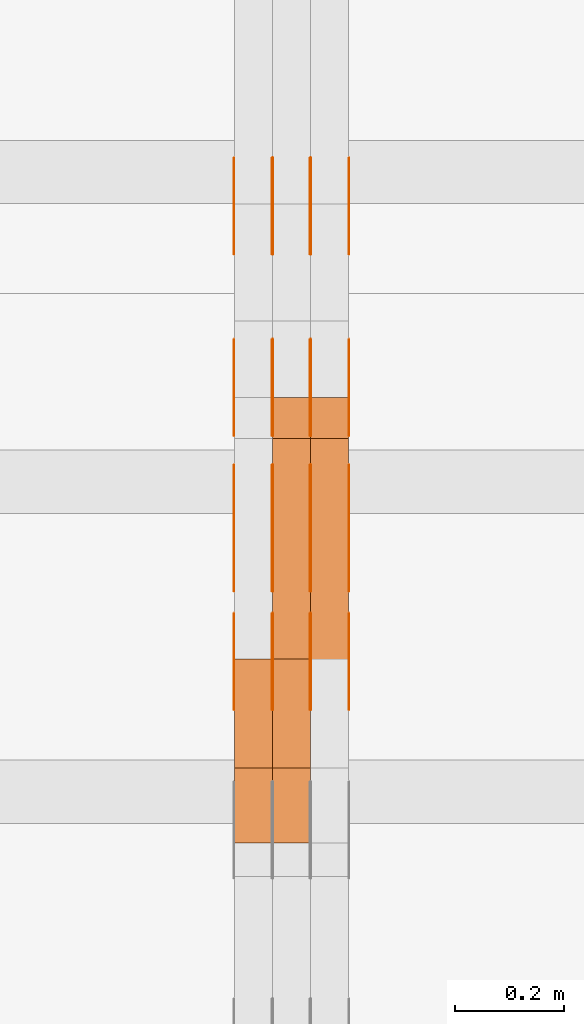
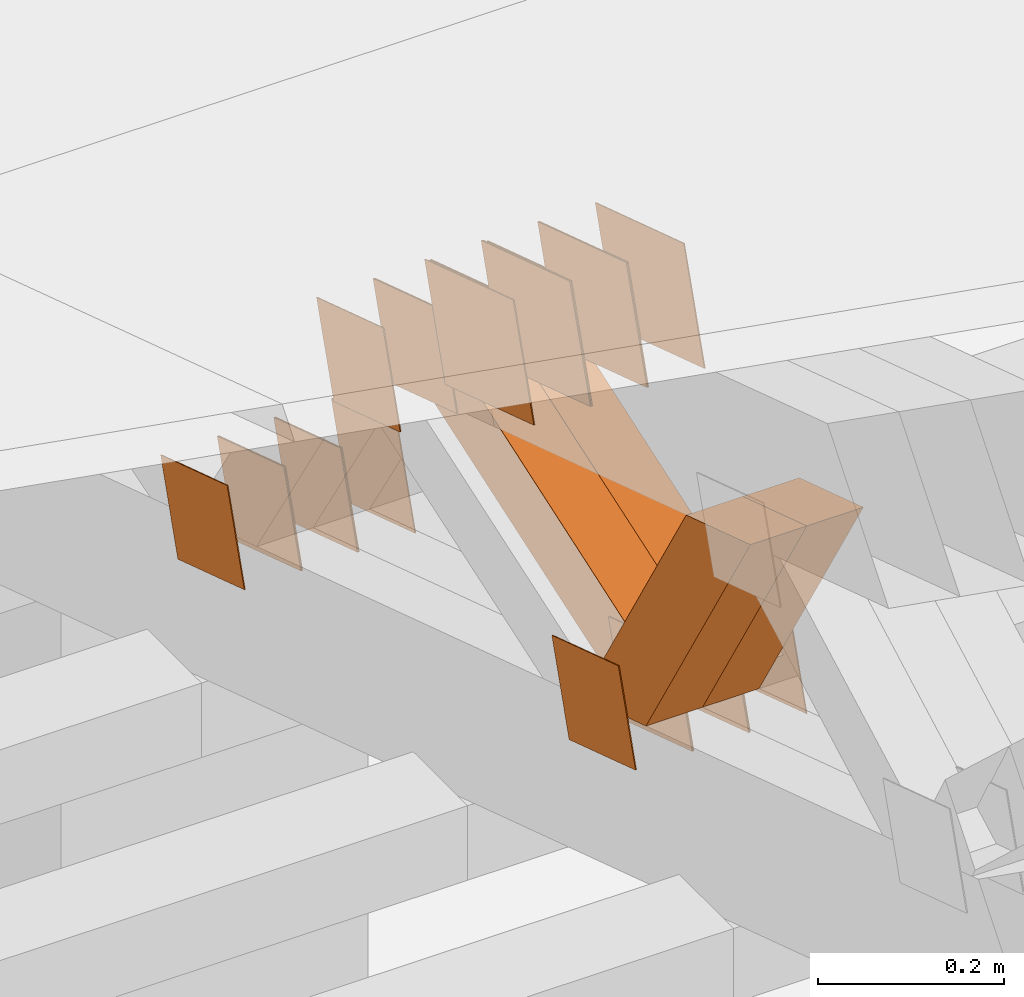
# One storey, part 226 of 385: 28 proxies.
"""IFC2X3 building model written with IfcOpenShell, lengths in millimetres."""

from ifc_helpers import new_model, entity, si_unit, converted_unit, derived_unit, direction, frame, origin, place, context, subcontext, project, spatial, polyline, outline, extrude, source, transform, mapped, material, type_object, type_shapes, element, save


model = new_model("IFC2X3")

# Units and contexts
model_context = context("Model", 3, precision=0.01, world=origin(), true_north=direction((6.12303176911189e-17, 1.0)))
body_context = subcontext(model_context, "Body", "Model", "MODEL_VIEW")
ifc_project = project(units=[si_unit("LENGTHUNIT", "METRE", prefix="MILLI"), si_unit("AREAUNIT", "SQUARE_METRE"), si_unit("VOLUMEUNIT", "CUBIC_METRE"), converted_unit("PLANEANGLEUNIT", "DEGREE", entity("IfcRatioMeasure", 0.0174532925199433), si_unit("PLANEANGLEUNIT", "RADIAN"), dimensions=[0, 0, 0, 0, 0, 0, 0]), si_unit("MASSUNIT", "GRAM", prefix="KILO"), derived_unit("MASSDENSITYUNIT", [(si_unit("MASSUNIT", "GRAM", prefix="KILO"), 1), (si_unit("LENGTHUNIT", "METRE"), -3)]), si_unit("TIMEUNIT", "SECOND"), si_unit("FREQUENCYUNIT", "HERTZ"), si_unit("THERMODYNAMICTEMPERATUREUNIT", "DEGREE_CELSIUS"), derived_unit("THERMALTRANSMITTANCEUNIT", [(si_unit("MASSUNIT", "GRAM", prefix="KILO"), 1), (si_unit("THERMODYNAMICTEMPERATUREUNIT", "KELVIN"), -1), (si_unit("TIMEUNIT", "SECOND"), -3)]), derived_unit("VOLUMETRICFLOWRATEUNIT", [(si_unit("LENGTHUNIT", "METRE"), 3), (si_unit("TIMEUNIT", "SECOND"), -1)]), si_unit("ELECTRICCURRENTUNIT", "AMPERE"), si_unit("ELECTRICVOLTAGEUNIT", "VOLT"), si_unit("POWERUNIT", "WATT"), si_unit("FORCEUNIT", "NEWTON", prefix="KILO"), si_unit("ILLUMINANCEUNIT", "LUX"), si_unit("LUMINOUSFLUXUNIT", "LUMEN"), si_unit("LUMINOUSINTENSITYUNIT", "CANDELA"), derived_unit("USERDEFINED", [(si_unit("MASSUNIT", "GRAM", prefix="KILO"), -1), (si_unit("LENGTHUNIT", "METRE"), -2), (si_unit("TIMEUNIT", "SECOND"), 3), (si_unit("LUMINOUSFLUXUNIT", "LUMEN"), 1)]), derived_unit("LINEARVELOCITYUNIT", [(si_unit("LENGTHUNIT", "METRE"), 1), (si_unit("TIMEUNIT", "SECOND"), -1)]), si_unit("PRESSUREUNIT", "PASCAL"), derived_unit("USERDEFINED", [(si_unit("LENGTHUNIT", "METRE"), -2), (si_unit("MASSUNIT", "GRAM", prefix="KILO"), 1), (si_unit("TIMEUNIT", "SECOND"), -2)])], contexts=[model_context])

# Site, building, storey
site_placement = place(None, origin())
site = spatial("IfcSite", under=ifc_project, at=site_placement, CompositionType="ELEMENT")
building_placement = place(site_placement, origin())
building = spatial("IfcBuilding", under=site, at=building_placement, CompositionType="ELEMENT")
storey_placement = place(building_placement, origin())
storey = spatial("IfcBuildingStorey", under=building, at=storey_placement, Name="Default", CompositionType="ELEMENT", Elevation=0.0)

# Proxies
ifc_material_1 = material(Name="IfcSurfaceStyle #349946")
building_element_proxy_type_1 = type_object("IfcBuildingElementProxyType", PredefinedType="NOTDEFINED", material=ifc_material_1)
shared_shape_1 = source(origin(), body_context, "Body", "SweptSolid", [
    extrude(outline(polyline([(-74.9998605591059, -59.9999264677526), (74.999875428623, -59.9999264677526), (74.9998605591068, 59.9999264677526), (-74.9998754286239, 59.9999264677526), (-74.9998605591059, -59.9999264677526)])), frame((75.0000889884782, 60.0000460315623, 0.0), z_axis=(0.0, 0.0, 1.0), x_axis=(-1.0, 0.0, 0.0)), (0.0, 0.0, 1.0), 1.3),
])
type_shapes(building_element_proxy_type_1, [shared_shape_1])
proxy_1_placement = place(building_placement, frame((27386.3, 20621.9679769682, 2241.76551219004), z_axis=(-1.0, 0.0, 0.0), x_axis=(0.0, -0.951056516295154, 0.309016994374948)))
element("IfcBuildingElementProxy", 1, at=proxy_1_placement, inside=storey, type_object=building_element_proxy_type_1, material=ifc_material_1, context=body_context, shape_type="MappedRepresentation", body=[
    mapped(shared_shape_1, transform((0.0, 0.0, 0.0), scale=1.0)),
])
ifc_material_2 = material(Name="IfcSurfaceStyle #349889")
building_element_proxy_type_2 = type_object("IfcBuildingElementProxyType", PredefinedType="NOTDEFINED", material=ifc_material_2)
shared_shape_2 = source(origin(), body_context, "Body", "SweptSolid", [
    extrude(outline(polyline([(-74.9998605591059, -59.9999264677526), (74.999875428623, -59.9999264677526), (74.9998605591068, 59.9999264677526), (-74.9998754286239, 59.9999264677526), (-74.9998605591059, -59.9999264677526)])), frame((75.0000889884782, 60.0000460315623, 0.0), z_axis=(0.0, 0.0, 1.0), x_axis=(-1.0, 0.0, 0.0)), (0.0, 0.0, 1.0), 1.3),
])
type_shapes(building_element_proxy_type_2, [shared_shape_2])
proxy_2_placement = place(building_placement, frame((27315.0, 20621.9679769682, 2241.76551219004), z_axis=(-1.0, 0.0, 0.0), x_axis=(0.0, -0.951056516295154, 0.309016994374948)))
element("IfcBuildingElementProxy", 2, at=proxy_2_placement, inside=storey, type_object=building_element_proxy_type_2, material=ifc_material_2, context=body_context, shape_type="MappedRepresentation", body=[
    mapped(shared_shape_2, transform((0.0, 0.0, 0.0), scale=1.0)),
])
ifc_material_3 = material(Name="IfcSurfaceStyle #349832")
building_element_proxy_type_3 = type_object("IfcBuildingElementProxyType", PredefinedType="NOTDEFINED", material=ifc_material_3)
shared_shape_3 = source(origin(), body_context, "Body", "SweptSolid", [
    extrude(outline(polyline([(-74.9998605591059, -59.9999264677526), (74.999875428623, -59.9999264677526), (74.9998605591068, 59.9999264677526), (-74.9998754286239, 59.9999264677526), (-74.9998605591059, -59.9999264677526)])), frame((75.0000889884782, 60.0000460315623, 0.0), z_axis=(0.0, 0.0, 1.0), x_axis=(-1.0, 0.0, 0.0)), (0.0, 0.0, 1.0), 1.3),
])
type_shapes(building_element_proxy_type_3, [shared_shape_3])
proxy_3_placement = place(building_placement, frame((27316.3, 20621.9679769682, 2241.76551219004), z_axis=(-1.0, 0.0, 0.0), x_axis=(0.0, -0.951056516295154, 0.309016994374948)))
element("IfcBuildingElementProxy", 3, at=proxy_3_placement, inside=storey, type_object=building_element_proxy_type_3, material=ifc_material_3, context=body_context, shape_type="MappedRepresentation", body=[
    mapped(shared_shape_3, transform((0.0, 0.0, 0.0), scale=1.0)),
])
ifc_material_4 = material(Name="IfcSurfaceStyle #349775")
building_element_proxy_type_4 = type_object("IfcBuildingElementProxyType", PredefinedType="NOTDEFINED", material=ifc_material_4)
shared_shape_4 = source(origin(), body_context, "Body", "SweptSolid", [
    extrude(outline(polyline([(-74.9998605591059, -59.9999264677526), (74.999875428623, -59.9999264677526), (74.9998605591068, 59.9999264677526), (-74.9998754286239, 59.9999264677526), (-74.9998605591059, -59.9999264677526)])), frame((75.0000889884782, 60.0000460315623, 0.0), z_axis=(0.0, 0.0, 1.0), x_axis=(-1.0, 0.0, 0.0)), (0.0, 0.0, 1.0), 1.29999999999999),
])
type_shapes(building_element_proxy_type_4, [shared_shape_4])
proxy_4_placement = place(building_placement, frame((27245.0, 20621.9679769682, 2241.76551219004), z_axis=(-1.0, 0.0, 0.0), x_axis=(0.0, -0.951056516295154, 0.309016994374948)))
element("IfcBuildingElementProxy", 4, at=proxy_4_placement, inside=storey, type_object=building_element_proxy_type_4, material=ifc_material_4, context=body_context, shape_type="MappedRepresentation", body=[
    mapped(shared_shape_4, transform((0.0, 0.0, 0.0), scale=1.0)),
])
ifc_material_5 = material(Name="IfcSurfaceStyle #349718")
building_element_proxy_type_5 = type_object("IfcBuildingElementProxyType", PredefinedType="NOTDEFINED", material=ifc_material_5)
shared_shape_5 = source(origin(), body_context, "Body", "SweptSolid", [
    extrude(outline(polyline([(-74.9998605591059, -59.9999264677526), (74.999875428623, -59.9999264677526), (74.9998605591068, 59.9999264677526), (-74.9998754286239, 59.9999264677526), (-74.9998605591059, -59.9999264677526)])), frame((75.0000889884782, 60.0000460315623, 0.0), z_axis=(0.0, 0.0, 1.0), x_axis=(-1.0, 0.0, 0.0)), (0.0, 0.0, 1.0), 1.29999999999999),
])
type_shapes(building_element_proxy_type_5, [shared_shape_5])
proxy_5_placement = place(building_placement, frame((27246.3, 20621.9679769682, 2241.76551219004), z_axis=(-1.0, 0.0, 0.0), x_axis=(0.0, -0.951056516295154, 0.309016994374948)))
element("IfcBuildingElementProxy", 5, at=proxy_5_placement, inside=storey, type_object=building_element_proxy_type_5, material=ifc_material_5, context=body_context, shape_type="MappedRepresentation", body=[
    mapped(shared_shape_5, transform((0.0, 0.0, 0.0), scale=1.0)),
])
ifc_material_6 = material(Name="IfcSurfaceStyle #349661")
building_element_proxy_type_6 = type_object("IfcBuildingElementProxyType", PredefinedType="NOTDEFINED", material=ifc_material_6)
shared_shape_6 = source(origin(), body_context, "Body", "SweptSolid", [
    extrude(outline(polyline([(-74.9998605591059, -59.9999264677526), (74.999875428623, -59.9999264677526), (74.9998605591068, 59.9999264677526), (-74.9998754286239, 59.9999264677526), (-74.9998605591059, -59.9999264677526)])), frame((75.0000889884782, 60.0000460315623, 0.0), z_axis=(0.0, 0.0, 1.0), x_axis=(-1.0, 0.0, 0.0)), (0.0, 0.0, 1.0), 1.29999999999999),
])
type_shapes(building_element_proxy_type_6, [shared_shape_6])
proxy_6_placement = place(building_placement, frame((27175.0, 20621.9679769682, 2241.76551219004), z_axis=(-1.0, 0.0, 0.0), x_axis=(0.0, -0.951056516295154, 0.309016994374948)))
element("IfcBuildingElementProxy", 6, at=proxy_6_placement, inside=storey, type_object=building_element_proxy_type_6, material=ifc_material_6, context=body_context, shape_type="MappedRepresentation", body=[
    mapped(shared_shape_6, transform((0.0, 0.0, 0.0), scale=1.0)),
])
ifc_material_7 = material(Name="IfcSurfaceStyle #348236")
building_element_proxy_type_7 = type_object("IfcBuildingElementProxyType", PredefinedType="NOTDEFINED", material=ifc_material_7)
shared_shape_7 = source(origin(), body_context, "Body", "SweptSolid", [
    extrude(outline(polyline([(-100.000260677523, -72.0000050220369), (100.000341220114, -72.0000050220369), (99.9997962944585, 72.0000050220369), (-99.9998768370492, 72.0000050220369), (-100.000260677523, -72.0000050220369)])), frame((100.000341220114, 72.0001826453454, 0.0), z_axis=(0.0, 0.0, 1.0), x_axis=(-1.0, 0.0, 0.0)), (0.0, 0.0, 1.0), 1.3),
])
type_shapes(building_element_proxy_type_7, [shared_shape_7])
proxy_7_placement = place(building_placement, frame((27386.3, 20382.8706354426, 2409.35285895246), z_axis=(-1.0, 0.0, 0.0), x_axis=(0.0, -0.951056516295154, 0.309016994374948)))
element("IfcBuildingElementProxy", 7, at=proxy_7_placement, inside=storey, type_object=building_element_proxy_type_7, material=ifc_material_7, context=body_context, shape_type="MappedRepresentation", body=[
    mapped(shared_shape_7, transform((0.0, 0.0, 0.0), scale=1.0)),
])
ifc_material_8 = material(Name="IfcSurfaceStyle #348179")
building_element_proxy_type_8 = type_object("IfcBuildingElementProxyType", PredefinedType="NOTDEFINED", material=ifc_material_8)
shared_shape_8 = source(origin(), body_context, "Body", "SweptSolid", [
    extrude(outline(polyline([(-100.000260677523, -72.0000050220369), (100.000341220114, -72.0000050220369), (99.9997962944585, 72.0000050220369), (-99.9998768370492, 72.0000050220369), (-100.000260677523, -72.0000050220369)])), frame((100.000341220114, 72.0001826453454, 0.0), z_axis=(0.0, 0.0, 1.0), x_axis=(-1.0, 0.0, 0.0)), (0.0, 0.0, 1.0), 1.3),
])
type_shapes(building_element_proxy_type_8, [shared_shape_8])
proxy_8_placement = place(building_placement, frame((27315.0, 20382.8706354426, 2409.35285895246), z_axis=(-1.0, 0.0, 0.0), x_axis=(0.0, -0.951056516295154, 0.309016994374948)))
element("IfcBuildingElementProxy", 8, at=proxy_8_placement, inside=storey, type_object=building_element_proxy_type_8, material=ifc_material_8, context=body_context, shape_type="MappedRepresentation", body=[
    mapped(shared_shape_8, transform((0.0, 0.0, 0.0), scale=1.0)),
])
ifc_material_9 = material(Name="IfcSurfaceStyle #348122")
building_element_proxy_type_9 = type_object("IfcBuildingElementProxyType", PredefinedType="NOTDEFINED", material=ifc_material_9)
shared_shape_9 = source(origin(), body_context, "Body", "SweptSolid", [
    extrude(outline(polyline([(-100.000260677523, -72.0000050220369), (100.000341220114, -72.0000050220369), (99.9997962944585, 72.0000050220369), (-99.9998768370492, 72.0000050220369), (-100.000260677523, -72.0000050220369)])), frame((100.000341220114, 72.0001826453454, 0.0), z_axis=(0.0, 0.0, 1.0), x_axis=(-1.0, 0.0, 0.0)), (0.0, 0.0, 1.0), 1.3),
])
type_shapes(building_element_proxy_type_9, [shared_shape_9])
proxy_9_placement = place(building_placement, frame((27316.3, 20382.8706354426, 2409.35285895246), z_axis=(-1.0, 0.0, 0.0), x_axis=(0.0, -0.951056516295154, 0.309016994374948)))
element("IfcBuildingElementProxy", 9, at=proxy_9_placement, inside=storey, type_object=building_element_proxy_type_9, material=ifc_material_9, context=body_context, shape_type="MappedRepresentation", body=[
    mapped(shared_shape_9, transform((0.0, 0.0, 0.0), scale=1.0)),
])
ifc_material_10 = material(Name="IfcSurfaceStyle #348065")
building_element_proxy_type_10 = type_object("IfcBuildingElementProxyType", PredefinedType="NOTDEFINED", material=ifc_material_10)
shared_shape_10 = source(origin(), body_context, "Body", "SweptSolid", [
    extrude(outline(polyline([(-100.000260677523, -72.0000050220369), (100.000341220114, -72.0000050220369), (99.9997962944585, 72.0000050220369), (-99.9998768370492, 72.0000050220369), (-100.000260677523, -72.0000050220369)])), frame((100.000341220114, 72.0001826453454, 0.0), z_axis=(0.0, 0.0, 1.0), x_axis=(-1.0, 0.0, 0.0)), (0.0, 0.0, 1.0), 1.29999999999998),
])
type_shapes(building_element_proxy_type_10, [shared_shape_10])
proxy_10_placement = place(building_placement, frame((27245.0, 20382.8706354426, 2409.35285895246), z_axis=(-1.0, 0.0, 0.0), x_axis=(0.0, -0.951056516295154, 0.309016994374948)))
element("IfcBuildingElementProxy", 10, at=proxy_10_placement, inside=storey, type_object=building_element_proxy_type_10, material=ifc_material_10, context=body_context, shape_type="MappedRepresentation", body=[
    mapped(shared_shape_10, transform((0.0, 0.0, 0.0), scale=1.0)),
])
ifc_material_11 = material(Name="IfcSurfaceStyle #348008")
building_element_proxy_type_11 = type_object("IfcBuildingElementProxyType", PredefinedType="NOTDEFINED", material=ifc_material_11)
shared_shape_11 = source(origin(), body_context, "Body", "SweptSolid", [
    extrude(outline(polyline([(-100.000260677523, -72.0000050220369), (100.000341220114, -72.0000050220369), (99.9997962944585, 72.0000050220369), (-99.9998768370492, 72.0000050220369), (-100.000260677523, -72.0000050220369)])), frame((100.000341220114, 72.0001826453454, 0.0), z_axis=(0.0, 0.0, 1.0), x_axis=(-1.0, 0.0, 0.0)), (0.0, 0.0, 1.0), 1.29999999999998),
])
type_shapes(building_element_proxy_type_11, [shared_shape_11])
proxy_11_placement = place(building_placement, frame((27246.3, 20382.8706354426, 2409.35285895246), z_axis=(-1.0, 0.0, 0.0), x_axis=(0.0, -0.951056516295154, 0.309016994374948)))
element("IfcBuildingElementProxy", 11, at=proxy_11_placement, inside=storey, type_object=building_element_proxy_type_11, material=ifc_material_11, context=body_context, shape_type="MappedRepresentation", body=[
    mapped(shared_shape_11, transform((0.0, 0.0, 0.0), scale=1.0)),
])
ifc_material_12 = material(Name="IfcSurfaceStyle #347951")
building_element_proxy_type_12 = type_object("IfcBuildingElementProxyType", PredefinedType="NOTDEFINED", material=ifc_material_12)
shared_shape_12 = source(origin(), body_context, "Body", "SweptSolid", [
    extrude(outline(polyline([(-100.000260677523, -72.0000050220369), (100.000341220114, -72.0000050220369), (99.9997962944585, 72.0000050220369), (-99.9998768370492, 72.0000050220369), (-100.000260677523, -72.0000050220369)])), frame((100.000341220114, 72.0001826453454, 0.0), z_axis=(0.0, 0.0, 1.0), x_axis=(-1.0, 0.0, 0.0)), (0.0, 0.0, 1.0), 1.29999999999999),
])
type_shapes(building_element_proxy_type_12, [shared_shape_12])
proxy_12_placement = place(building_placement, frame((27175.0, 20382.8706354426, 2409.35285895246), z_axis=(-1.0, 0.0, 0.0), x_axis=(0.0, -0.951056516295154, 0.309016994374948)))
element("IfcBuildingElementProxy", 12, at=proxy_12_placement, inside=storey, type_object=building_element_proxy_type_12, material=ifc_material_12, context=body_context, shape_type="MappedRepresentation", body=[
    mapped(shared_shape_12, transform((0.0, 0.0, 0.0), scale=1.0)),
])
ifc_material_13 = material(Name="IfcSurfaceStyle #341738")
building_element_proxy_type_13 = type_object("IfcBuildingElementProxyType", PredefinedType="NOTDEFINED", material=ifc_material_13)
shared_shape_13 = source(origin(), body_context, "Body", "SweptSolid", [
    extrude(outline(polyline([(-74.9998605591118, -59.9999264677598), (74.9998754286171, -59.9999264677598), (74.9998605591136, 59.9999264677598), (-74.9998754286189, 59.9999264677598), (-74.9998605591118, -59.9999264677598)])), frame((75.0000347664736, 60.0000016373434, 0.0), z_axis=(0.0, 0.0, 1.0), x_axis=(-1.0, 0.0, 0.0)), (0.0, 0.0, 1.0), 1.3),
])
type_shapes(building_element_proxy_type_13, [shared_shape_13])
proxy_13_placement = place(building_placement, frame((27386.3, 20117.0890328685, 2105.40814929196), z_axis=(-1.0, 0.0, 0.0), x_axis=(0.0, -0.951056516295124, 0.309016994375039)))
element("IfcBuildingElementProxy", 13, at=proxy_13_placement, inside=storey, type_object=building_element_proxy_type_13, material=ifc_material_13, context=body_context, shape_type="MappedRepresentation", body=[
    mapped(shared_shape_13, transform((0.0, 0.0, 0.0), scale=1.0)),
])
ifc_material_14 = material(Name="IfcSurfaceStyle #341681")
building_element_proxy_type_14 = type_object("IfcBuildingElementProxyType", PredefinedType="NOTDEFINED", material=ifc_material_14)
shared_shape_14 = source(origin(), body_context, "Body", "SweptSolid", [
    extrude(outline(polyline([(-74.9998605591118, -59.9999264677598), (74.9998754286171, -59.9999264677598), (74.9998605591136, 59.9999264677598), (-74.9998754286189, 59.9999264677598), (-74.9998605591118, -59.9999264677598)])), frame((75.0000347664736, 60.0000016373434, 0.0), z_axis=(0.0, 0.0, 1.0), x_axis=(-1.0, 0.0, 0.0)), (0.0, 0.0, 1.0), 1.3),
])
type_shapes(building_element_proxy_type_14, [shared_shape_14])
proxy_14_placement = place(building_placement, frame((27315.0, 20117.0890328685, 2105.40814929196), z_axis=(-1.0, 0.0, 0.0), x_axis=(0.0, -0.951056516295124, 0.309016994375039)))
element("IfcBuildingElementProxy", 14, at=proxy_14_placement, inside=storey, type_object=building_element_proxy_type_14, material=ifc_material_14, context=body_context, shape_type="MappedRepresentation", body=[
    mapped(shared_shape_14, transform((0.0, 0.0, 0.0), scale=1.0)),
])
ifc_material_15 = material(Name="IfcSurfaceStyle #341624")
building_element_proxy_type_15 = type_object("IfcBuildingElementProxyType", PredefinedType="NOTDEFINED", material=ifc_material_15)
shared_shape_15 = source(origin(), body_context, "Body", "SweptSolid", [
    extrude(outline(polyline([(-74.9998605591118, -59.9999264677598), (74.9998754286171, -59.9999264677598), (74.9998605591136, 59.9999264677598), (-74.9998754286189, 59.9999264677598), (-74.9998605591118, -59.9999264677598)])), frame((75.0000347664736, 60.0000016373434, 0.0), z_axis=(0.0, 0.0, 1.0), x_axis=(-1.0, 0.0, 0.0)), (0.0, 0.0, 1.0), 1.3),
])
type_shapes(building_element_proxy_type_15, [shared_shape_15])
proxy_15_placement = place(building_placement, frame((27316.3, 20117.0890328685, 2105.40814929196), z_axis=(-1.0, 0.0, 0.0), x_axis=(0.0, -0.951056516295124, 0.309016994375039)))
element("IfcBuildingElementProxy", 15, at=proxy_15_placement, inside=storey, type_object=building_element_proxy_type_15, material=ifc_material_15, context=body_context, shape_type="MappedRepresentation", body=[
    mapped(shared_shape_15, transform((0.0, 0.0, 0.0), scale=1.0)),
])
ifc_material_16 = material(Name="IfcSurfaceStyle #341567")
building_element_proxy_type_16 = type_object("IfcBuildingElementProxyType", PredefinedType="NOTDEFINED", material=ifc_material_16)
shared_shape_16 = source(origin(), body_context, "Body", "SweptSolid", [
    extrude(outline(polyline([(-74.9998605591118, -59.9999264677598), (74.9998754286171, -59.9999264677598), (74.9998605591136, 59.9999264677598), (-74.9998754286189, 59.9999264677598), (-74.9998605591118, -59.9999264677598)])), frame((75.0000347664736, 60.0000016373434, 0.0), z_axis=(0.0, 0.0, 1.0), x_axis=(-1.0, 0.0, 0.0)), (0.0, 0.0, 1.0), 1.29999999999999),
])
type_shapes(building_element_proxy_type_16, [shared_shape_16])
proxy_16_placement = place(building_placement, frame((27245.0, 20117.0890328685, 2105.40814929196), z_axis=(-1.0, 0.0, 0.0), x_axis=(0.0, -0.951056516295124, 0.309016994375039)))
element("IfcBuildingElementProxy", 16, at=proxy_16_placement, inside=storey, type_object=building_element_proxy_type_16, material=ifc_material_16, context=body_context, shape_type="MappedRepresentation", body=[
    mapped(shared_shape_16, transform((0.0, 0.0, 0.0), scale=1.0)),
])
ifc_material_17 = material(Name="IfcSurfaceStyle #341510")
building_element_proxy_type_17 = type_object("IfcBuildingElementProxyType", PredefinedType="NOTDEFINED", material=ifc_material_17)
shared_shape_17 = source(origin(), body_context, "Body", "SweptSolid", [
    extrude(outline(polyline([(-74.9998605591118, -59.9999264677598), (74.9998754286171, -59.9999264677598), (74.9998605591136, 59.9999264677598), (-74.9998754286189, 59.9999264677598), (-74.9998605591118, -59.9999264677598)])), frame((75.0000347664736, 60.0000016373434, 0.0), z_axis=(0.0, 0.0, 1.0), x_axis=(-1.0, 0.0, 0.0)), (0.0, 0.0, 1.0), 1.29999999999999),
])
type_shapes(building_element_proxy_type_17, [shared_shape_17])
proxy_17_placement = place(building_placement, frame((27246.3, 20117.0890328685, 2105.40814929196), z_axis=(-1.0, 0.0, 0.0), x_axis=(0.0, -0.951056516295124, 0.309016994375039)))
element("IfcBuildingElementProxy", 17, at=proxy_17_placement, inside=storey, type_object=building_element_proxy_type_17, material=ifc_material_17, context=body_context, shape_type="MappedRepresentation", body=[
    mapped(shared_shape_17, transform((0.0, 0.0, 0.0), scale=1.0)),
])
ifc_material_18 = material(Name="IfcSurfaceStyle #341453")
building_element_proxy_type_18 = type_object("IfcBuildingElementProxyType", PredefinedType="NOTDEFINED", material=ifc_material_18)
shared_shape_18 = source(origin(), body_context, "Body", "SweptSolid", [
    extrude(outline(polyline([(-74.9998605591118, -59.9999264677598), (74.9998754286171, -59.9999264677598), (74.9998605591136, 59.9999264677598), (-74.9998754286189, 59.9999264677598), (-74.9998605591118, -59.9999264677598)])), frame((75.0000347664736, 60.0000016373434, 0.0), z_axis=(0.0, 0.0, 1.0), x_axis=(-1.0, 0.0, 0.0)), (0.0, 0.0, 1.0), 1.29999999999999),
])
type_shapes(building_element_proxy_type_18, [shared_shape_18])
proxy_18_placement = place(building_placement, frame((27175.0, 20117.0890328685, 2105.40814929196), z_axis=(-1.0, 0.0, 0.0), x_axis=(0.0, -0.951056516295124, 0.309016994375039)))
element("IfcBuildingElementProxy", 18, at=proxy_18_placement, inside=storey, type_object=building_element_proxy_type_18, material=ifc_material_18, context=body_context, shape_type="MappedRepresentation", body=[
    mapped(shared_shape_18, transform((0.0, 0.0, 0.0), scale=1.0)),
])
ifc_material_19 = material(Name="IfcSurfaceStyle #341396")
building_element_proxy_type_19 = type_object("IfcBuildingElementProxyType", PredefinedType="NOTDEFINED", material=ifc_material_19)
shared_shape_19 = source(origin(), body_context, "Body", "SweptSolid", [
    extrude(outline(polyline([(-74.9998794200132, -59.999984515643), (74.9998565677174, -59.999984515643), (74.9998794200123, 59.999984515643), (-74.9998565677165, 59.999984515643), (-74.9998794200132, -59.999984515643)])), frame((75.0002235343086, 60.0000596852268, 0.0), z_axis=(0.0, 0.0, 1.0), x_axis=(-1.0, 0.0, 0.0)), (0.0, 0.0, 1.0), 1.3),
])
type_shapes(building_element_proxy_type_19, [shared_shape_19])
proxy_19_placement = place(building_placement, frame((27386.3, 20956.2317725846, 1832.75404405346), z_axis=(-1.0, 0.0, 0.0), x_axis=(0.0, -0.951056516295124, 0.309016994375039)))
element("IfcBuildingElementProxy", 19, at=proxy_19_placement, inside=storey, type_object=building_element_proxy_type_19, material=ifc_material_19, context=body_context, shape_type="MappedRepresentation", body=[
    mapped(shared_shape_19, transform((0.0, 0.0, 0.0), scale=1.0)),
])
ifc_material_20 = material(Name="IfcSurfaceStyle #341339")
building_element_proxy_type_20 = type_object("IfcBuildingElementProxyType", PredefinedType="NOTDEFINED", material=ifc_material_20)
shared_shape_20 = source(origin(), body_context, "Body", "SweptSolid", [
    extrude(outline(polyline([(-74.9998794200132, -59.999984515643), (74.9998565677174, -59.999984515643), (74.9998794200123, 59.999984515643), (-74.9998565677165, 59.999984515643), (-74.9998794200132, -59.999984515643)])), frame((75.0002235343086, 60.0000596852268, 0.0), z_axis=(0.0, 0.0, 1.0), x_axis=(-1.0, 0.0, 0.0)), (0.0, 0.0, 1.0), 1.3),
])
type_shapes(building_element_proxy_type_20, [shared_shape_20])
proxy_20_placement = place(building_placement, frame((27315.0, 20956.2317725846, 1832.75404405346), z_axis=(-1.0, 0.0, 0.0), x_axis=(0.0, -0.951056516295124, 0.309016994375039)))
element("IfcBuildingElementProxy", 20, at=proxy_20_placement, inside=storey, type_object=building_element_proxy_type_20, material=ifc_material_20, context=body_context, shape_type="MappedRepresentation", body=[
    mapped(shared_shape_20, transform((0.0, 0.0, 0.0), scale=1.0)),
])
ifc_material_21 = material(Name="IfcSurfaceStyle #341282")
building_element_proxy_type_21 = type_object("IfcBuildingElementProxyType", PredefinedType="NOTDEFINED", material=ifc_material_21)
shared_shape_21 = source(origin(), body_context, "Body", "SweptSolid", [
    extrude(outline(polyline([(-74.9998794200132, -59.999984515643), (74.9998565677174, -59.999984515643), (74.9998794200123, 59.999984515643), (-74.9998565677165, 59.999984515643), (-74.9998794200132, -59.999984515643)])), frame((75.0002235343086, 60.0000596852268, 0.0), z_axis=(0.0, 0.0, 1.0), x_axis=(-1.0, 0.0, 0.0)), (0.0, 0.0, 1.0), 1.3),
])
type_shapes(building_element_proxy_type_21, [shared_shape_21])
proxy_21_placement = place(building_placement, frame((27316.3, 20956.2317725846, 1832.75404405346), z_axis=(-1.0, 0.0, 0.0), x_axis=(0.0, -0.951056516295124, 0.309016994375039)))
element("IfcBuildingElementProxy", 21, at=proxy_21_placement, inside=storey, type_object=building_element_proxy_type_21, material=ifc_material_21, context=body_context, shape_type="MappedRepresentation", body=[
    mapped(shared_shape_21, transform((0.0, 0.0, 0.0), scale=1.0)),
])
ifc_material_22 = material(Name="IfcSurfaceStyle #341225")
building_element_proxy_type_22 = type_object("IfcBuildingElementProxyType", PredefinedType="NOTDEFINED", material=ifc_material_22)
shared_shape_22 = source(origin(), body_context, "Body", "SweptSolid", [
    extrude(outline(polyline([(-74.9998794200132, -59.999984515643), (74.9998565677174, -59.999984515643), (74.9998794200123, 59.999984515643), (-74.9998565677165, 59.999984515643), (-74.9998794200132, -59.999984515643)])), frame((75.0002235343086, 60.0000596852268, 0.0), z_axis=(0.0, 0.0, 1.0), x_axis=(-1.0, 0.0, 0.0)), (0.0, 0.0, 1.0), 1.29999999999999),
])
type_shapes(building_element_proxy_type_22, [shared_shape_22])
proxy_22_placement = place(building_placement, frame((27245.0, 20956.2317725846, 1832.75404405346), z_axis=(-1.0, 0.0, 0.0), x_axis=(0.0, -0.951056516295124, 0.309016994375039)))
element("IfcBuildingElementProxy", 22, at=proxy_22_placement, inside=storey, type_object=building_element_proxy_type_22, material=ifc_material_22, context=body_context, shape_type="MappedRepresentation", body=[
    mapped(shared_shape_22, transform((0.0, 0.0, 0.0), scale=1.0)),
])
ifc_material_23 = material(Name="IfcSurfaceStyle #341168")
building_element_proxy_type_23 = type_object("IfcBuildingElementProxyType", PredefinedType="NOTDEFINED", material=ifc_material_23)
shared_shape_23 = source(origin(), body_context, "Body", "SweptSolid", [
    extrude(outline(polyline([(-74.9998794200132, -59.999984515643), (74.9998565677174, -59.999984515643), (74.9998794200123, 59.999984515643), (-74.9998565677165, 59.999984515643), (-74.9998794200132, -59.999984515643)])), frame((75.0002235343086, 60.0000596852268, 0.0), z_axis=(0.0, 0.0, 1.0), x_axis=(-1.0, 0.0, 0.0)), (0.0, 0.0, 1.0), 1.29999999999999),
])
type_shapes(building_element_proxy_type_23, [shared_shape_23])
proxy_23_placement = place(building_placement, frame((27246.3, 20956.2317725846, 1832.75404405346), z_axis=(-1.0, 0.0, 0.0), x_axis=(0.0, -0.951056516295124, 0.309016994375039)))
element("IfcBuildingElementProxy", 23, at=proxy_23_placement, inside=storey, type_object=building_element_proxy_type_23, material=ifc_material_23, context=body_context, shape_type="MappedRepresentation", body=[
    mapped(shared_shape_23, transform((0.0, 0.0, 0.0), scale=1.0)),
])
ifc_material_24 = material(Name="IfcSurfaceStyle #341111")
building_element_proxy_type_24 = type_object("IfcBuildingElementProxyType", PredefinedType="NOTDEFINED", material=ifc_material_24)
shared_shape_24 = source(origin(), body_context, "Body", "SweptSolid", [
    extrude(outline(polyline([(-74.9998794200132, -59.999984515643), (74.9998565677174, -59.999984515643), (74.9998794200123, 59.999984515643), (-74.9998565677165, 59.999984515643), (-74.9998794200132, -59.999984515643)])), frame((75.0002235343086, 60.0000596852268, 0.0), z_axis=(0.0, 0.0, 1.0), x_axis=(-1.0, 0.0, 0.0)), (0.0, 0.0, 1.0), 1.29999999999999),
])
type_shapes(building_element_proxy_type_24, [shared_shape_24])
proxy_24_placement = place(building_placement, frame((27175.0, 20956.2317725846, 1832.75404405346), z_axis=(-1.0, 0.0, 0.0), x_axis=(0.0, -0.951056516295124, 0.309016994375039)))
element("IfcBuildingElementProxy", 24, at=proxy_24_placement, inside=storey, type_object=building_element_proxy_type_24, material=ifc_material_24, context=body_context, shape_type="MappedRepresentation", body=[
    mapped(shared_shape_24, transform((0.0, 0.0, 0.0), scale=1.0)),
])
ifc_material_25 = material(Name="IfcSurfaceStyle #324464")
building_element_proxy_type_25 = type_object("IfcBuildingElementProxyType", Name="T1-W34 324462", PredefinedType="NOTDEFINED", material=ifc_material_25)
shared_shape_25 = source(origin(), body_context, "Body", "SweptSolid", [
    extrude(outline(polyline([(-197.657161937088, -47.499796538607), (193.17680883218, -47.499796538607), (182.92464491562, -1.98968224184526e-05), (128.354123102956, 47.4998064870182), (-306.798414913668, 47.4998064870182), (-197.657161937088, -47.499796538607)])), frame((193.176852028916, 47.4998566383869, 0.0), z_axis=(0.0, 0.0, 1.0), x_axis=(-1.0, 0.0, 0.0)), (0.0, 0.0, 1.0), 70.0),
])
type_shapes(building_element_proxy_type_25, [shared_shape_25])
proxy_25_placement = place(building_placement, frame((27315.0, 19987.8030409043, 2165.75390635484), z_axis=(-1.0, 0.0, 0.0), x_axis=(0.0, -0.514479403471631, 0.857502736674044)))
element("IfcBuildingElementProxy", 25, at=proxy_25_placement, inside=storey, type_object=building_element_proxy_type_25, material=ifc_material_25, Name="T1-W34", context=body_context, shape_type="MappedRepresentation", body=[
    mapped(shared_shape_25, transform((0.0, 0.0, 0.0), scale=1.0)),
])
ifc_material_26 = material(Name="IfcSurfaceStyle #324398")
building_element_proxy_type_26 = type_object("IfcBuildingElementProxyType", Name="T1-W34 324396", PredefinedType="NOTDEFINED", material=ifc_material_26)
shared_shape_26 = source(origin(), body_context, "Body", "SweptSolid", [
    extrude(outline(polyline([(-197.657161937088, -47.499796538607), (193.17680883218, -47.499796538607), (182.92464491562, -1.98968224184526e-05), (128.354123102956, 47.4998064870182), (-306.798414913668, 47.4998064870182), (-197.657161937088, -47.499796538607)])), frame((193.176852028916, 47.4998566383869, 0.0), z_axis=(0.0, 0.0, 1.0), x_axis=(-1.0, 0.0, 0.0)), (0.0, 0.0, 1.0), 70.0),
])
type_shapes(building_element_proxy_type_26, [shared_shape_26])
proxy_26_placement = place(building_placement, frame((27245.0, 19987.8030409043, 2165.75390635484), z_axis=(-1.0, 0.0, 0.0), x_axis=(0.0, -0.514479403471631, 0.857502736674044)))
element("IfcBuildingElementProxy", 26, at=proxy_26_placement, inside=storey, type_object=building_element_proxy_type_26, material=ifc_material_26, Name="T1-W34", context=body_context, shape_type="MappedRepresentation", body=[
    mapped(shared_shape_26, transform((0.0, 0.0, 0.0), scale=1.0)),
])
ifc_material_27 = material(Name="IfcSurfaceStyle #324134")
building_element_proxy_type_27 = type_object("IfcBuildingElementProxyType", Name="T1-W26 324132", PredefinedType="NOTDEFINED", material=ifc_material_27)
shared_shape_27 = source(origin(), body_context, "Body", "SweptSolid", [
    extrude(outline(polyline([(-339.390941716546, -47.5001331548025), (137.738864791781, -47.5001331548025), (201.272298560955, 6.02772073885038e-05), (212.703852542003, 47.5001030161988), (-212.324074178193, 47.5001030161988), (-339.390941716546, -47.5001331548025)])), frame((212.703852542003, 47.5001030161988, 0.0), z_axis=(0.0, 0.0, 1.0), x_axis=(-1.0, 0.0, 0.0)), (0.0, 0.0, 1.0), 70.0),
])
type_shapes(building_element_proxy_type_27, [shared_shape_27])
proxy_27_placement = place(building_placement, frame((27385.0, 20576.541015625, 2286.80981445313), z_axis=(-1.0, 0.0, 0.0), x_axis=(0.0, -0.946743816465327, -0.321987804093053)))
element("IfcBuildingElementProxy", 27, at=proxy_27_placement, inside=storey, type_object=building_element_proxy_type_27, material=ifc_material_27, Name="T1-W26", context=body_context, shape_type="MappedRepresentation", body=[
    mapped(shared_shape_27, transform((0.0, 0.0, 0.0), scale=1.0)),
])
ifc_material_28 = material(Name="IfcSurfaceStyle #324068")
building_element_proxy_type_28 = type_object("IfcBuildingElementProxyType", Name="T1-W26 324066", PredefinedType="NOTDEFINED", material=ifc_material_28)
shared_shape_28 = source(origin(), body_context, "Body", "SweptSolid", [
    extrude(outline(polyline([(-339.390941716546, -47.5001331548025), (137.738864791781, -47.5001331548025), (201.272298560955, 6.02772073885038e-05), (212.703852542003, 47.5001030161988), (-212.324074178193, 47.5001030161988), (-339.390941716546, -47.5001331548025)])), frame((212.703852542003, 47.5001030161988, 0.0), z_axis=(0.0, 0.0, 1.0), x_axis=(-1.0, 0.0, 0.0)), (0.0, 0.0, 1.0), 70.0),
])
type_shapes(building_element_proxy_type_28, [shared_shape_28])
proxy_28_placement = place(building_placement, frame((27315.0, 20576.541015625, 2286.80981445313), z_axis=(-1.0, 0.0, 0.0), x_axis=(0.0, -0.946743816465327, -0.321987804093053)))
element("IfcBuildingElementProxy", 28, at=proxy_28_placement, inside=storey, type_object=building_element_proxy_type_28, material=ifc_material_28, Name="T1-W26", context=body_context, shape_type="MappedRepresentation", body=[
    mapped(shared_shape_28, transform((0.0, 0.0, 0.0), scale=1.0)),
])

save(model, "model.ifc")
